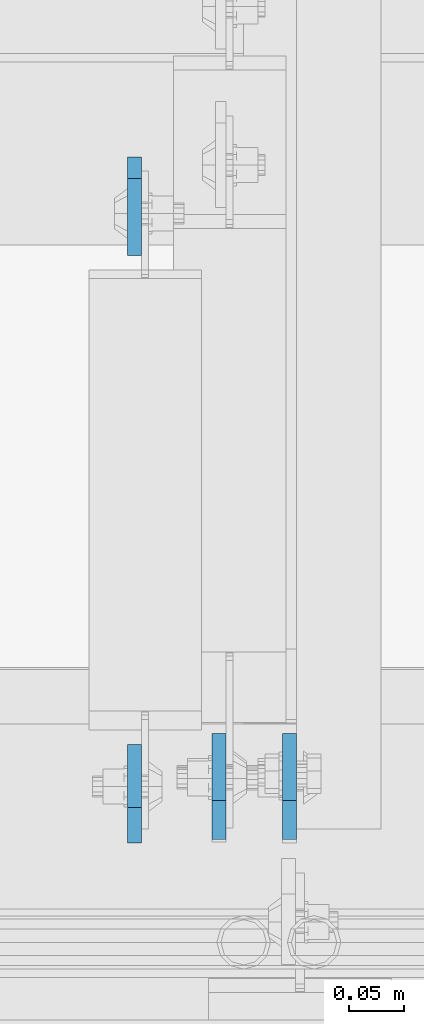
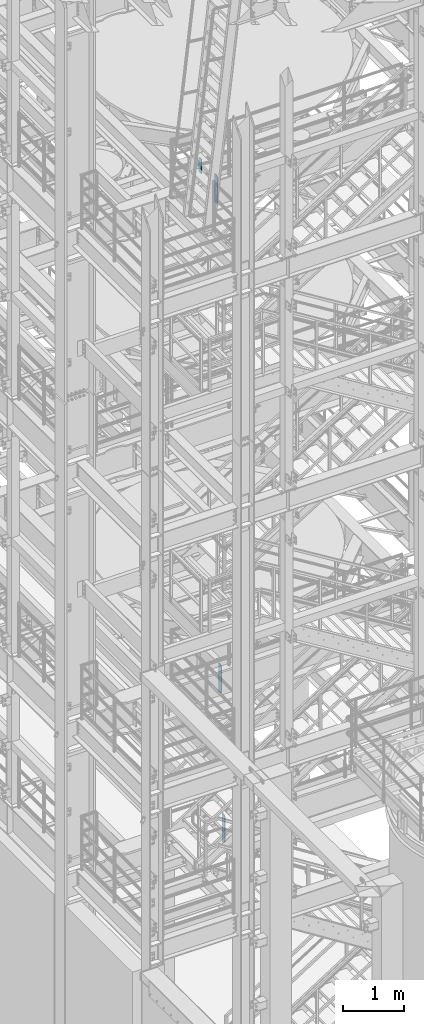
# One storey, part 1475 of 1876: 4 plates, 4 elements without a shape of their own.
"""IFC2X3 building model written with IfcOpenShell, lengths in millimetres."""

import ifcopenshell
import ifcopenshell.guid

model = None  # the IFC model being written
_history = None  # IfcOwnerHistory: only IFC2X3 demands one
_inside = {}  # id of a spatial element -> (the spatial element, [elements in it])
_under = {}  # id of a project, library or spatial element -> (it, [spatial elements below it])
_declared = {}  # id of a project -> (the project, [libraries it declares])
_typed = {}  # id of a type object -> (the type object, [elements of that type])
_made_of = {}  # id of a material, layer set ... -> (it, [elements and type objects made of it])


def new_model(schema):
    """Start an empty IFC model of exactly this schema.

    Asked for "IFC4X3", IfcOpenShell would pick the latest addendum, in which some entities
    have other attributes; the version numbers below select the first issue.
    IFC2X3 requires an IfcOwnerHistory on every rooted entity: one is made here for all.
    """
    global model, _history
    if schema == "IFC4X3":
        model = ifcopenshell.file(schema_version=(4, 3, 0, 0))
    else:
        model = ifcopenshell.file(schema=schema)
    _inside.clear()
    _under.clear()
    _declared.clear()
    _typed.clear()
    _made_of.clear()
    _history = None
    if model.schema == "IFC2X3":
        org = make("IfcOrganization", Name="unknown")
        user = make(
            "IfcPersonAndOrganization",
            ThePerson=make("IfcPerson", FamilyName="unknown"),
            TheOrganization=org,
        )
        app = make(
            "IfcApplication",
            ApplicationDeveloper=org,
            Version="unknown",
            ApplicationFullName="unknown",
            ApplicationIdentifier="unknown",
        )
        _history = make(
            "IfcOwnerHistory",
            OwningUser=user,
            OwningApplication=app,
            ChangeAction="ADDED",
            CreationDate=0,
        )
    return model


def make(cls, **values):
    """One entity of the class cls with the attributes given. An attribute that is None is left unset."""
    return model.create_entity(
        cls, **{name: value for name, value in values.items() if value is not None}
    )


def rooted(cls, **values):
    """An entity with a GlobalId (a new one), such as an element, a storey or a relation."""
    return make(cls, GlobalId=ifcopenshell.guid.new(), OwnerHistory=_history, **values)


def si_unit(unit_type, name, prefix=None):
    """IfcSIUnit, for example si_unit("LENGTHUNIT", "METRE", prefix="MILLI")."""
    return make("IfcSIUnit", UnitType=unit_type, Prefix=prefix, Name=name)


def assignment(units):
    """IfcUnitAssignment: the units of a project."""
    return None if units is None else make("IfcUnitAssignment", Units=units)


def point(xyz):
    """IfcCartesianPoint."""
    return None if xyz is None else make("IfcCartesianPoint", Coordinates=xyz)


def direction(xyz):
    """IfcDirection."""
    return None if xyz is None else make("IfcDirection", DirectionRatios=xyz)


def frame(location, z_axis=None, x_axis=None):
    """IfcAxis2Placement3D, a coordinate frame: its origin and axes. An axis left out is left unset."""
    return make(
        "IfcAxis2Placement3D",
        Location=point(location),
        Axis=direction(z_axis),
        RefDirection=direction(x_axis),
    )


def origin_with_axes():
    """The frame at (0, 0, 0) with the z axis (0, 0, 1) and the x axis (1, 0, 0) written out."""
    return frame((0.0, 0.0, 0.0), z_axis=(0.0, 0.0, 1.0), x_axis=(1.0, 0.0, 0.0))


def place(relative_to, where):
    """IfcLocalPlacement: puts the frame where relative to a parent placement (None: the world)."""
    return make(
        "IfcLocalPlacement", PlacementRelTo=relative_to, RelativePlacement=where
    )


def context(
    kind, dimensions, precision=None, world=None, true_north=None, identifier=None
):
    """IfcGeometricRepresentationContext, for example the 3D "Model" context."""
    return make(
        "IfcGeometricRepresentationContext",
        ContextIdentifier=identifier,
        ContextType=kind,
        CoordinateSpaceDimension=dimensions,
        Precision=precision,
        WorldCoordinateSystem=world,
        TrueNorth=true_north,
    )


def subcontext(parent, identifier, kind, view, scale=None):
    """IfcGeometricRepresentationSubContext, for example "Body" below "Model"."""
    return make(
        "IfcGeometricRepresentationSubContext",
        ContextIdentifier=identifier,
        ContextType=kind,
        ParentContext=parent,
        TargetScale=scale,
        TargetView=view,
    )


def project(units=None, contexts=None):
    """IfcProject with its units and contexts."""
    return rooted(
        "IfcProject",
        Name="project",
        RepresentationContexts=contexts,
        UnitsInContext=assignment(units),
    )


def spatial(cls, under=None, at=None, **own):
    """A site, building, storey or space (cls), placed at a placement, below another one or the project."""
    s = rooted(cls, ObjectPlacement=at, **own)
    if under is not None:
        _under.setdefault(under.id(), (under, []))[1].append(s)
    return s


def faces_of(points, faces, orient=None, outer=None):
    """IfcFace entities. A face is a list of loops; a loop is a list of indices into points, from 0.

    orient and outer hold one flag for each loop. By default every Orientation is true, the
    first loop of a face is its IfcFaceOuterBound and the others are IfcFaceBound.
    """
    made = []
    for i, loops in enumerate(faces):
        bounds = []
        for j, loop in enumerate(loops):
            is_outer = j == 0 if outer is None else outer[i][j]
            bounds.append(
                make(
                    "IfcFaceOuterBound" if is_outer else "IfcFaceBound",
                    Bound=make("IfcPolyLoop", Polygon=[points[k] for k in loop]),
                    Orientation=True if orient is None else orient[i][j],
                )
            )
        made.append(make("IfcFace", Bounds=bounds))
    return made


def faceted_brep(points, faces, orient=None, outer=None, voids=None):
    """IfcFacetedBrep: a solid bounded by flat faces; with voids (closed shells), ...WithVoids."""
    shared = [point(p) for p in points]
    hull = make("IfcClosedShell", CfsFaces=faces_of(shared, faces, orient, outer))
    if voids is None:
        return make("IfcFacetedBrep", Outer=hull)
    return make(
        "IfcFacetedBrepWithVoids",
        Outer=hull,
        Voids=[
            make(cls, CfsFaces=faces_of(shared, fs, o, b)) for cls, fs, o, b in voids
        ],
    )


def shape(context_of_items, identifier, shape_type, items):
    """IfcShapeRepresentation: the items that make up one representation, for example the "Body"."""
    return make(
        "IfcShapeRepresentation",
        ContextOfItems=context_of_items,
        RepresentationIdentifier=identifier,
        RepresentationType=shape_type,
        Items=items,
    )


def material(Name=None, Category=None):
    """IfcMaterial."""
    return make("IfcMaterial", Name=Name, Category=Category)


def made_of(thing, what):
    """Note that an element or type object is made of a material, layer set ...; save() writes the relation."""
    if what is not None:
        _made_of.setdefault(what.id(), (what, []))[1].append(thing)
    return thing


def type_object(cls, material=None, **own):
    """A type object (cls), such as IfcWallType, which elements share."""
    return made_of(rooted(cls, **own), material)


def element(
    cls,
    number,
    at=None,
    inside=None,
    cuts=None,
    type_object=None,
    material=None,
    context=None,
    identifier="Body",
    shape_type=None,
    held_by="IfcProductDefinitionShape",
    body=None,
    shapes=None,
    **own,
):
    """One element of the class cls, such as IfcWall. Its Tag is "e" and its number.

    at: its placement. inside: the storey or other place that contains it. cuts: it is an
    opening in that element (IfcRelVoidsElement). A single representation is given by context,
    identifier, shape_type and body (its items); several are given by shapes. held_by: the class
    of the entity that holds the representations. save() writes the other relations.
    """
    e = rooted(cls, Tag="e%d" % number, ObjectPlacement=at, **own)
    if body is not None:
        shapes = [shape(context, identifier, shape_type, body)]
    if shapes is not None:
        e.Representation = make(held_by, Representations=shapes)
    if inside is not None:
        _inside.setdefault(inside.id(), (inside, []))[1].append(e)
    if cuts is not None:
        rooted(
            "IfcRelVoidsElement", RelatingBuildingElement=cuts, RelatedOpeningElement=e
        )
    if type_object is not None:
        _typed.setdefault(type_object.id(), (type_object, []))[1].append(e)
    return made_of(e, material)


def aggregate(whole, parts):
    """IfcRelAggregates: a whole, such as a stair, and the parts it consists of."""
    return rooted("IfcRelAggregates", RelatingObject=whole, RelatedObjects=parts)


def save(model, path):
    """Write the relations noted so far, then the file.

    IfcRelAggregates (storeys below a building ...), IfcRelContainedInSpatialStructure (elements
    in a storey), IfcRelDefinesByType, IfcRelAssociatesMaterial and IfcRelDeclares: one each for
    every whole, place, type object, material and project.
    """
    for whole, parts in _under.values():
        aggregate(whole, parts)
    for where, things in _inside.values():
        rooted(
            "IfcRelContainedInSpatialStructure",
            RelatedElements=things,
            RelatingStructure=where,
        )
    for kind, things in _typed.values():
        rooted("IfcRelDefinesByType", RelatedObjects=things, RelatingType=kind)
    for what, things in _made_of.values():
        rooted("IfcRelAssociatesMaterial", RelatedObjects=things, RelatingMaterial=what)
    for by, libraries in _declared.values():
        rooted("IfcRelDeclares", RelatingContext=by, RelatedDefinitions=libraries)
    model.write(path)


model = new_model("IFC2X3")

# Units and contexts
model_context = context("Model", 3, precision=1e-05, world=origin_with_axes())
body_context = subcontext(model_context, "Body", "Model", "MODEL_VIEW")
ifc_project = project(units=[si_unit("LENGTHUNIT", "METRE", prefix="MILLI"), si_unit("AREAUNIT", "SQUARE_METRE"), si_unit("VOLUMEUNIT", "CUBIC_METRE"), si_unit("MASSUNIT", "GRAM", prefix="KILO"), si_unit("TIMEUNIT", "SECOND"), si_unit("PLANEANGLEUNIT", "RADIAN"), si_unit("SOLIDANGLEUNIT", "STERADIAN"), si_unit("THERMODYNAMICTEMPERATUREUNIT", "DEGREE_CELSIUS"), si_unit("LUMINOUSINTENSITYUNIT", "LUMEN")], contexts=[model_context])

# Site, building, storey
site_placement = place(None, origin_with_axes())
site = spatial("IfcSite", under=ifc_project, at=site_placement, CompositionType="ELEMENT")
building_placement = place(site_placement, origin_with_axes())
building = spatial("IfcBuilding", under=site, at=building_placement, Name="Undefined", CompositionType="ELEMENT")
storey_placement = place(building_placement, origin_with_axes())
storey = spatial("IfcBuildingStorey", under=building, at=storey_placement, Name="Undefined", CompositionType="ELEMENT", Elevation=0.0)

# Assembly, plate
assembly_1_placement = place(storey_placement, origin_with_axes())
assembly_1 = element("IfcElementAssembly", 1, at=assembly_1_placement, inside=storey, Name="BEAM", AssemblyPlace="NOTDEFINED", PredefinedType="RIGID_FRAME")
ifc_material = material(Name="STEEL/A36")
plate_type_1 = type_object("IfcPlateType", PredefinedType="NOTDEFINED")
plate_1_placement = place(assembly_1_placement, frame((2708.27499990463, -4564.85625, 17386.3), z_axis=(0.0, 0.0, 1.0), x_axis=(0.0, 1.0, 0.0)))
plate_1 = element("IfcPlate", 2, at=plate_1_placement, type_object=plate_type_1, material=ifc_material, Name="PLATE", context=body_context, shape_type="Brep", body=[
    faceted_brep([(0.0, -6.34999999999991, 31.75), (0.0, -6.34999999999991, 539.75), (0.0, 6.34999999999991, 539.75), (0.0, 6.34999999999991, 31.75), (31.75, -6.34999999999991, 571.5), (31.75, 6.34999999999991, 571.5), (88.9000015258789, -6.34999999999991, 571.5), (88.9000015258789, 6.34999999999991, 571.5), (88.9000015258789, -6.34999999999991, 0.0), (88.9000015258789, 6.34999999999991, 0.0), (31.75, -6.34999999999991, 0.0), (31.75, 6.34999999999991, 0.0)], [[[0, 1, 2, 3]], [[1, 4, 5, 2]], [[4, 6, 7, 5]], [[6, 8, 9, 7]], [[8, 10, 11, 9]], [[10, 0, 3, 11]], [[5, 7, 9, 11, 3, 2]], [[10, 8, 6, 4, 1, 0]]]),
])
aggregate(assembly_1, [plate_1])

assembly_2_placement = place(storey_placement, origin_with_axes())
assembly_2 = element("IfcElementAssembly", 3, at=assembly_2_placement, inside=storey, Name="BEAM", AssemblyPlace="NOTDEFINED", PredefinedType="RIGID_FRAME")
plate_2_placement = place(assembly_2_placement, frame((2708.27499988935, -3946.525, 17679.9875), z_axis=(0.0, 0.0, 1.0), x_axis=(0.0, -1.0, 0.0)))
plate_2 = element("IfcPlate", 4, at=plate_2_placement, type_object=plate_type_1, material=ifc_material, Name="PLATE", context=body_context, shape_type="Brep", body=[
    faceted_brep([(0.0, -6.35000000000196, 19.0499992370605), (9.09494701772928e-13, -6.34999999999832, 273.050006866455), (-2.72848410531878e-12, 6.34999999999923, 273.050006866455), (0.0, 6.35000000000105, 19.0499992370605), (19.0499992370578, -6.35000000000696, 292.100006103516), (19.049999237056, 6.3499999999915, 292.100006103516), (88.9000015258789, -6.35000000000036, 292.100006103516), (88.9000015258789, 6.35000000000036, 292.100006103516), (88.9000015258789, -6.34999999999991, 0.0), (88.9000015258789, 6.34999999999991, 0.0), (19.0499992370642, -6.35000000000105, 0.0), (19.0499992370633, 6.35000000000105, 0.0)], [[[0, 1, 2, 3]], [[1, 4, 5, 2]], [[4, 6, 7, 5]], [[6, 8, 9, 7]], [[8, 10, 11, 9]], [[10, 0, 3, 11]], [[5, 7, 9, 11, 3, 2]], [[10, 8, 6, 4, 1, 0]]]),
])
aggregate(assembly_2, [plate_2])

assembly_3_placement = place(storey_placement, origin_with_axes())
assembly_3 = element("IfcElementAssembly", 5, at=assembly_3_placement, inside=storey, Name="BEAM", AssemblyPlace="NOTDEFINED", PredefinedType="RIGID_FRAME")
plate_type_2 = type_object("IfcPlateType", PredefinedType="NOTDEFINED")
plate_3_placement = place(assembly_3_placement, frame((2784.47499990463, -4561.68125, 7543.8), z_axis=(0.0, 0.0, 1.0), x_axis=(0.0, 1.0, 0.0)))
plate_3 = element("IfcPlate", 6, at=plate_3_placement, type_object=plate_type_2, material=ifc_material, Name="PLATE", context=body_context, shape_type="Brep", body=[
    faceted_brep([(0.0, -6.34999999999991, 34.9249992370605), (0.0, -6.35000000000036, 538.162475585938), (0.0, 6.35000000000036, 538.162475585938), (0.0, 6.34999999999991, 34.9249992370605), (34.9249992370605, -6.34999999999991, 573.087524414062), (34.9249992370605, 6.34999999999991, 573.087524414062), (95.25, -6.34999999999991, 573.087524414062), (95.25, 6.34999999999991, 573.087524414062), (95.25, -6.35000000000036, 0.0), (95.25, 6.35000000000036, 0.0), (34.9249992370605, -6.34999999999991, 0.0), (34.9249992370605, 6.34999999999991, 0.0)], [[[0, 1, 2, 3]], [[1, 4, 5, 2]], [[4, 6, 7, 5]], [[6, 8, 9, 7]], [[8, 10, 11, 9]], [[10, 0, 3, 11]], [[5, 7, 9, 11, 3, 2]], [[10, 8, 6, 4, 1, 0]]]),
])
aggregate(assembly_3, [plate_3])

assembly_4_placement = place(storey_placement, origin_with_axes())
assembly_4 = element("IfcElementAssembly", 7, at=assembly_4_placement, inside=storey, Name="BEAM", AssemblyPlace="NOTDEFINED", PredefinedType="RIGID_FRAME")
plate_4_placement = place(assembly_4_placement, frame((2847.975, -4561.68125, 4521.2), z_axis=(0.0, 0.0, 1.0), x_axis=(0.0, 1.0, 0.0)))
plate_4 = element("IfcPlate", 8, at=plate_4_placement, type_object=plate_type_2, material=ifc_material, Name="PLATE", context=body_context, shape_type="Brep", body=[
    faceted_brep([(0.0, -6.34999999999991, 34.9249992370605), (0.0, -6.35000000000036, 538.162475585938), (0.0, 6.35000000000036, 538.162475585938), (0.0, 6.34999999999991, 34.9249992370605), (34.9249992370605, -6.34999999999991, 573.087524414062), (34.9249992370605, 6.34999999999991, 573.087524414062), (95.25, -6.34999999999991, 573.087524414062), (95.25, 6.34999999999991, 573.087524414062), (95.25, -6.35000000000036, 0.0), (95.25, 6.35000000000036, 0.0), (34.9249992370605, -6.34999999999991, 0.0), (34.9249992370605, 6.34999999999991, 0.0)], [[[0, 1, 2, 3]], [[1, 4, 5, 2]], [[4, 6, 7, 5]], [[6, 8, 9, 7]], [[8, 10, 11, 9]], [[10, 0, 3, 11]], [[5, 7, 9, 11, 3, 2]], [[10, 8, 6, 4, 1, 0]]]),
])
aggregate(assembly_4, [plate_4])

save(model, "model.ifc")
